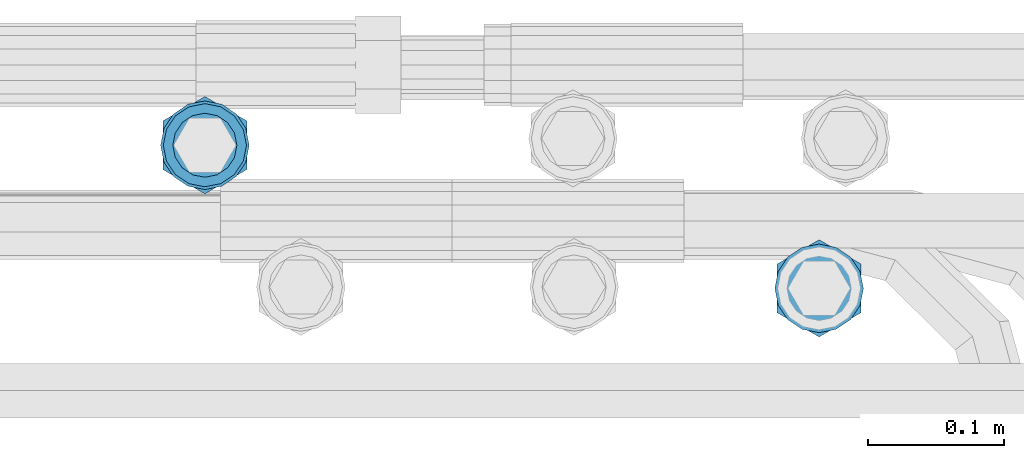
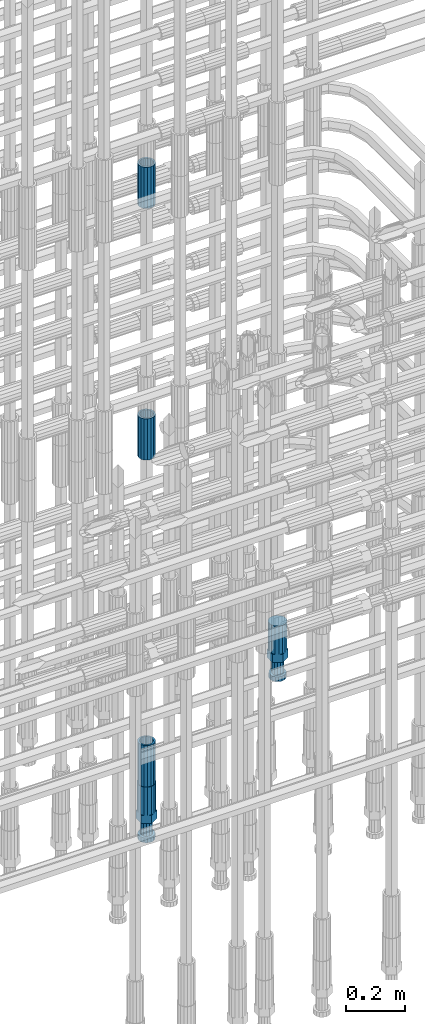
# One storey, part 74 of 119: 5 beams.
"""IFC2X3 building model written with IfcOpenShell, lengths in millimetres."""

import ifcopenshell
import ifcopenshell.guid

model = None  # the IFC model being written
_history = None  # IfcOwnerHistory: only IFC2X3 demands one
_inside = {}  # id of a spatial element -> (the spatial element, [elements in it])
_under = {}  # id of a project, library or spatial element -> (it, [spatial elements below it])
_declared = {}  # id of a project -> (the project, [libraries it declares])
_typed = {}  # id of a type object -> (the type object, [elements of that type])
_made_of = {}  # id of a material, layer set ... -> (it, [elements and type objects made of it])


def new_model(schema):
    """Start an empty IFC model of exactly this schema.

    Asked for "IFC4X3", IfcOpenShell would pick the latest addendum, in which some entities
    have other attributes; the version numbers below select the first issue.
    IFC2X3 requires an IfcOwnerHistory on every rooted entity: one is made here for all.
    """
    global model, _history
    if schema == "IFC4X3":
        model = ifcopenshell.file(schema_version=(4, 3, 0, 0))
    else:
        model = ifcopenshell.file(schema=schema)
    _inside.clear()
    _under.clear()
    _declared.clear()
    _typed.clear()
    _made_of.clear()
    _history = None
    if model.schema == "IFC2X3":
        org = make("IfcOrganization", Name="unknown")
        user = make(
            "IfcPersonAndOrganization",
            ThePerson=make("IfcPerson", FamilyName="unknown"),
            TheOrganization=org,
        )
        app = make(
            "IfcApplication",
            ApplicationDeveloper=org,
            Version="unknown",
            ApplicationFullName="unknown",
            ApplicationIdentifier="unknown",
        )
        _history = make(
            "IfcOwnerHistory",
            OwningUser=user,
            OwningApplication=app,
            ChangeAction="ADDED",
            CreationDate=0,
        )
    return model


def make(cls, **values):
    """One entity of the class cls with the attributes given. An attribute that is None is left unset."""
    return model.create_entity(
        cls, **{name: value for name, value in values.items() if value is not None}
    )


def rooted(cls, **values):
    """An entity with a GlobalId (a new one), such as an element, a storey or a relation."""
    return make(cls, GlobalId=ifcopenshell.guid.new(), OwnerHistory=_history, **values)


def si_unit(unit_type, name, prefix=None):
    """IfcSIUnit, for example si_unit("LENGTHUNIT", "METRE", prefix="MILLI")."""
    return make("IfcSIUnit", UnitType=unit_type, Prefix=prefix, Name=name)


def assignment(units):
    """IfcUnitAssignment: the units of a project."""
    return None if units is None else make("IfcUnitAssignment", Units=units)


def point(xyz):
    """IfcCartesianPoint."""
    return None if xyz is None else make("IfcCartesianPoint", Coordinates=xyz)


def direction(xyz):
    """IfcDirection."""
    return None if xyz is None else make("IfcDirection", DirectionRatios=xyz)


def frame(location, z_axis=None, x_axis=None):
    """IfcAxis2Placement3D, a coordinate frame: its origin and axes. An axis left out is left unset."""
    return make(
        "IfcAxis2Placement3D",
        Location=point(location),
        Axis=direction(z_axis),
        RefDirection=direction(x_axis),
    )


def origin_with_axes():
    """The frame at (0, 0, 0) with the z axis (0, 0, 1) and the x axis (1, 0, 0) written out."""
    return frame((0.0, 0.0, 0.0), z_axis=(0.0, 0.0, 1.0), x_axis=(1.0, 0.0, 0.0))


def place(relative_to, where):
    """IfcLocalPlacement: puts the frame where relative to a parent placement (None: the world)."""
    return make(
        "IfcLocalPlacement", PlacementRelTo=relative_to, RelativePlacement=where
    )


def context(
    kind, dimensions, precision=None, world=None, true_north=None, identifier=None
):
    """IfcGeometricRepresentationContext, for example the 3D "Model" context."""
    return make(
        "IfcGeometricRepresentationContext",
        ContextIdentifier=identifier,
        ContextType=kind,
        CoordinateSpaceDimension=dimensions,
        Precision=precision,
        WorldCoordinateSystem=world,
        TrueNorth=true_north,
    )


def subcontext(parent, identifier, kind, view, scale=None):
    """IfcGeometricRepresentationSubContext, for example "Body" below "Model"."""
    return make(
        "IfcGeometricRepresentationSubContext",
        ContextIdentifier=identifier,
        ContextType=kind,
        ParentContext=parent,
        TargetScale=scale,
        TargetView=view,
    )


def project(units=None, contexts=None):
    """IfcProject with its units and contexts."""
    return rooted(
        "IfcProject",
        Name="project",
        RepresentationContexts=contexts,
        UnitsInContext=assignment(units),
    )


def spatial(cls, under=None, at=None, **own):
    """A site, building, storey or space (cls), placed at a placement, below another one or the project."""
    s = rooted(cls, ObjectPlacement=at, **own)
    if under is not None:
        _under.setdefault(under.id(), (under, []))[1].append(s)
    return s


def faces_of(points, faces, orient=None, outer=None):
    """IfcFace entities. A face is a list of loops; a loop is a list of indices into points, from 0.

    orient and outer hold one flag for each loop. By default every Orientation is true, the
    first loop of a face is its IfcFaceOuterBound and the others are IfcFaceBound.
    """
    made = []
    for i, loops in enumerate(faces):
        bounds = []
        for j, loop in enumerate(loops):
            is_outer = j == 0 if outer is None else outer[i][j]
            bounds.append(
                make(
                    "IfcFaceOuterBound" if is_outer else "IfcFaceBound",
                    Bound=make("IfcPolyLoop", Polygon=[points[k] for k in loop]),
                    Orientation=True if orient is None else orient[i][j],
                )
            )
        made.append(make("IfcFace", Bounds=bounds))
    return made


def faceted_brep(points, faces, orient=None, outer=None, voids=None):
    """IfcFacetedBrep: a solid bounded by flat faces; with voids (closed shells), ...WithVoids."""
    shared = [point(p) for p in points]
    hull = make("IfcClosedShell", CfsFaces=faces_of(shared, faces, orient, outer))
    if voids is None:
        return make("IfcFacetedBrep", Outer=hull)
    return make(
        "IfcFacetedBrepWithVoids",
        Outer=hull,
        Voids=[
            make(cls, CfsFaces=faces_of(shared, fs, o, b)) for cls, fs, o, b in voids
        ],
    )


def shape(context_of_items, identifier, shape_type, items):
    """IfcShapeRepresentation: the items that make up one representation, for example the "Body"."""
    return make(
        "IfcShapeRepresentation",
        ContextOfItems=context_of_items,
        RepresentationIdentifier=identifier,
        RepresentationType=shape_type,
        Items=items,
    )


def material(Name=None, Category=None):
    """IfcMaterial."""
    return make("IfcMaterial", Name=Name, Category=Category)


def made_of(thing, what):
    """Note that an element or type object is made of a material, layer set ...; save() writes the relation."""
    if what is not None:
        _made_of.setdefault(what.id(), (what, []))[1].append(thing)
    return thing


def type_object(cls, material=None, **own):
    """A type object (cls), such as IfcWallType, which elements share."""
    return made_of(rooted(cls, **own), material)


def element(
    cls,
    number,
    at=None,
    inside=None,
    cuts=None,
    type_object=None,
    material=None,
    context=None,
    identifier="Body",
    shape_type=None,
    held_by="IfcProductDefinitionShape",
    body=None,
    shapes=None,
    **own,
):
    """One element of the class cls, such as IfcWall. Its Tag is "e" and its number.

    at: its placement. inside: the storey or other place that contains it. cuts: it is an
    opening in that element (IfcRelVoidsElement). A single representation is given by context,
    identifier, shape_type and body (its items); several are given by shapes. held_by: the class
    of the entity that holds the representations. save() writes the other relations.
    """
    e = rooted(cls, Tag="e%d" % number, ObjectPlacement=at, **own)
    if body is not None:
        shapes = [shape(context, identifier, shape_type, body)]
    if shapes is not None:
        e.Representation = make(held_by, Representations=shapes)
    if inside is not None:
        _inside.setdefault(inside.id(), (inside, []))[1].append(e)
    if cuts is not None:
        rooted(
            "IfcRelVoidsElement", RelatingBuildingElement=cuts, RelatedOpeningElement=e
        )
    if type_object is not None:
        _typed.setdefault(type_object.id(), (type_object, []))[1].append(e)
    return made_of(e, material)


def aggregate(whole, parts):
    """IfcRelAggregates: a whole, such as a stair, and the parts it consists of."""
    return rooted("IfcRelAggregates", RelatingObject=whole, RelatedObjects=parts)


def save(model, path):
    """Write the relations noted so far, then the file.

    IfcRelAggregates (storeys below a building ...), IfcRelContainedInSpatialStructure (elements
    in a storey), IfcRelDefinesByType, IfcRelAssociatesMaterial and IfcRelDeclares: one each for
    every whole, place, type object, material and project.
    """
    for whole, parts in _under.values():
        aggregate(whole, parts)
    for where, things in _inside.values():
        rooted(
            "IfcRelContainedInSpatialStructure",
            RelatedElements=things,
            RelatingStructure=where,
        )
    for kind, things in _typed.values():
        rooted("IfcRelDefinesByType", RelatedObjects=things, RelatingType=kind)
    for what, things in _made_of.values():
        rooted("IfcRelAssociatesMaterial", RelatedObjects=things, RelatingMaterial=what)
    for by, libraries in _declared.values():
        rooted("IfcRelDeclares", RelatingContext=by, RelatedDefinitions=libraries)
    model.write(path)


model = new_model("IFC2X3")

# Units and contexts
model_context = context("Model", 3, precision=1e-05, world=origin_with_axes())
body_context = subcontext(model_context, "Body", "Model", "MODEL_VIEW")
ifc_project = project(units=[si_unit("LENGTHUNIT", "METRE", prefix="MILLI"), si_unit("AREAUNIT", "SQUARE_METRE"), si_unit("VOLUMEUNIT", "CUBIC_METRE"), si_unit("MASSUNIT", "GRAM", prefix="KILO"), si_unit("TIMEUNIT", "SECOND"), si_unit("PLANEANGLEUNIT", "RADIAN"), si_unit("SOLIDANGLEUNIT", "STERADIAN"), si_unit("THERMODYNAMICTEMPERATUREUNIT", "DEGREE_CELSIUS"), si_unit("LUMINOUSINTENSITYUNIT", "LUMEN")], contexts=[model_context])

# Site, building, storey
site_placement = place(None, origin_with_axes())
site = spatial("IfcSite", under=ifc_project, at=site_placement, CompositionType="ELEMENT")
building_placement = place(site_placement, origin_with_axes())
building = spatial("IfcBuilding", under=site, at=building_placement, Name="Undefined", CompositionType="ELEMENT")
storey_placement = place(building_placement, origin_with_axes())
storey = spatial("IfcBuildingStorey", under=building, at=storey_placement, Name="Undefined", CompositionType="ELEMENT", Elevation=0.0)

# Beams
ifc_material = material(Name="STEEL/S275")
beam_type_1 = type_object("IfcBeamType", PredefinedType="NOTDEFINED")
beam_1_placement = place(storey_placement, frame((2035854.99840131, 6206340.98567718, 19667.7157291637), z_axis=(1.0, 0.0, 0.0), x_axis=(0.0, 0.0, 1.0)))
element("IfcBeam", 1, at=beam_1_placement, inside=storey, type_object=beam_type_1, material=ifc_material, Name="AG40N", context=body_context, shape_type="Brep", body=[
    faceted_brep([(1.62981450557709e-09, -23.4999999990687, 0.0), (7.45058059692383e-09, -21.7111690142192, 8.99306066057534), (170.000002125278, -21.711168999318, 8.99306066022245), (170.000002127141, -23.4999999844003, -3.66071617463604e-10), (4.65661287307739e-09, -16.6170093587134, 16.6170093578889), (170.000002122484, -16.6170093440451, 16.6170093575288), (1.86264514923096e-09, -8.99306066217832, 21.7111690140277), (170.000002118759, -8.99306064750999, 21.7111690136603), (2.3283064365387e-10, 9.31322574615479e-10, 23.5), (170.000002114102, 1.28056854009628e-08, 23.4999999996485), (-6.51925802230835e-09, 8.99306065868586, 21.7111690140241), (170.00000211224, 8.99306067335419, 21.7111690136639), (-7.45058059692383e-09, 16.6170093561523, 16.6170093578853), (170.000002109446, 16.6170093708206, 16.6170093575324), (-9.31322574615479e-09, 21.711169013055, 8.99306066057534), (170.000002108514, 21.7111690277234, 8.99306066022245), (-1.16415321826935e-09, 23.5000000009313, 0.0), (170.000002108514, 23.5000000144355, -3.66071617463604e-10), (-8.38190317153931e-09, 21.7111690151505, -8.99306066059444), (170.000002110377, 21.7111690300517, -8.9930606609546), (-5.58793544769287e-09, 16.6170093598776, -16.6170093579008), (170.000002113171, 16.6170093745459, -16.6170093582609), (-9.31322574615479e-10, 8.99306066334248, -21.7111690140396), (170.000002115965, 8.99306067801081, -21.7111690143961), (2.3283064365387e-10, 9.31322574615479e-10, -23.5), (170.00000211969, 1.7927959561348e-08, -23.5000000003843), (5.58793544769287e-09, -8.99306065752171, -21.7111690140396), (170.000002123415, -8.99306064285338, -21.7111690143961), (8.38190317153931e-09, -16.6170093549881, -16.6170093579008), (170.000002125278, -16.6170093403198, -16.6170093582646), (9.31322574615479e-09, -21.7111690121237, -8.99306066059444), (170.000002127141, -21.7111689972226, -8.9930606609546), (1.11758708953857e-08, -30.4999999990687, -9.54969436861575e-12), (1.30385160446167e-08, -28.1783257392235, -11.6718446871514), (170.000002129003, -28.1783257243223, -11.6718446875116), (170.000002129935, -30.4999999841675, -3.66071617463604e-10), (1.02445483207703e-08, -21.5667568228673, -21.5667568262129), (170.000002128072, -21.566756808199, -21.5667568265694), (7.45058059692383e-09, -11.6718446831219, -28.1783257416196), (170.000002125278, -11.6718446684536, -28.1783257419834), (3.72529029846191e-09, 3.95812094211578e-09, -30.5000000000277), (170.00000211969, 1.83936208486557e-08, -30.5000000003879), (-9.31322574615479e-10, 11.6718446905725, -28.1783257416232), (170.000002115965, 11.6718447052408, -28.1783257419797), (-6.51925802230835e-09, 21.5667568286881, -21.5667568262093), (170.000002110377, 21.5667568433564, -21.5667568265694), (-9.31322574615479e-09, 28.178325742716, -11.6718446871478), (170.000002108514, 28.1783257573843, -11.6718446875079), (-1.21071934700012e-08, 30.5, -5.91171556152403e-12), (170.000002106652, 30.5000000144355, -3.62433638656512e-10), (-1.21071934700012e-08, 28.1783257401548, 11.6718446871359), (170.00000210572, 28.1783257548232, 11.6718446867794), (-1.02445483207703e-08, 21.5667568240315, 21.5667568261974), (170.000002107583, 21.566756838467, 21.5667568258409), (-7.45058059692383e-09, 11.671844684286, 28.1783257416041), (170.000002110377, 11.6718446989544, 28.178325741244), (-2.79396772384644e-09, -2.56113708019257e-09, 30.5000000000159), (170.000002114102, 1.18743628263474e-08, 30.4999999996558), (1.86264514923096e-09, -11.6718446896411, 28.1783257416114), (170.000002118759, -11.67184467474, 28.178325741244), (7.45058059692383e-09, -21.5667568275239, 21.5667568261974), (170.000002123415, -21.5667568126228, 21.5667568258373), (1.02445483207703e-08, -28.1783257415518, 11.6718446871359), (170.000002127141, -28.1783257271163, 11.6718446867794)], [[[0, 1, 2, 3]], [[1, 4, 5, 2]], [[4, 6, 7, 5]], [[6, 8, 9, 7]], [[8, 10, 11, 9]], [[10, 12, 13, 11]], [[12, 14, 15, 13]], [[14, 16, 17, 15]], [[16, 18, 19, 17]], [[18, 20, 21, 19]], [[20, 22, 23, 21]], [[22, 24, 25, 23]], [[24, 26, 27, 25]], [[26, 28, 29, 27]], [[28, 30, 31, 29]], [[30, 0, 3, 31]], [[32, 33, 34, 35]], [[33, 36, 37, 34]], [[36, 38, 39, 37]], [[38, 40, 41, 39]], [[40, 42, 43, 41]], [[42, 44, 45, 43]], [[44, 46, 47, 45]], [[46, 48, 49, 47]], [[48, 50, 51, 49]], [[50, 52, 53, 51]], [[52, 54, 55, 53]], [[54, 56, 57, 55]], [[56, 58, 59, 57]], [[58, 60, 61, 59]], [[60, 62, 63, 61]], [[62, 32, 35, 63]], [[37, 39, 41, 43, 45, 47, 49, 51, 53, 55, 57, 59, 61, 63, 35, 34], [5, 7, 9, 11, 13, 15, 17, 19, 21, 23, 25, 27, 29, 31, 3, 2]], [[62, 60, 58, 56, 54, 52, 50, 48, 46, 44, 42, 40, 38, 36, 33, 32], [30, 28, 26, 24, 22, 20, 18, 16, 14, 12, 10, 8, 6, 4, 1, 0]]]),
])
beam_2_placement = place(storey_placement, frame((2035854.99840131, 6206340.98567718, 18490.9668583146), z_axis=(-0.99999999999998, 1.98000110685822e-07, 0.0), x_axis=(0.0, 0.0, -1.0)))
element("IfcBeam", 2, at=beam_2_placement, inside=storey, type_object=beam_type_1, material=ifc_material, Name="AG40N", context=body_context, shape_type="Brep", body=[
    faceted_brep([(1.62981450557709e-09, -23.4999999990687, 0.0), (7.45058059692383e-09, -21.7111690142192, 8.99306066057534), (170.000002125278, -21.711168999318, 8.99306066022245), (170.000002127141, -23.4999999844003, -3.66071617463604e-10), (4.65661287307739e-09, -16.6170093587134, 16.6170093578889), (170.000002122484, -16.6170093440451, 16.6170093575288), (1.86264514923096e-09, -8.99306066217832, 21.7111690140277), (170.000002118759, -8.99306064750999, 21.7111690136603), (2.3283064365387e-10, 9.31322574615479e-10, 23.5), (170.000002114102, 1.28056854009628e-08, 23.4999999996485), (-6.51925802230835e-09, 8.99306065868586, 21.7111690140241), (170.00000211224, 8.99306067335419, 21.7111690136639), (-7.45058059692383e-09, 16.6170093561523, 16.6170093578853), (170.000002109446, 16.6170093708206, 16.6170093575324), (-9.31322574615479e-09, 21.711169013055, 8.99306066057534), (170.000002108514, 21.7111690277234, 8.99306066022245), (-1.16415321826935e-09, 23.5000000009313, 0.0), (170.000002108514, 23.5000000144355, -3.66071617463604e-10), (-8.38190317153931e-09, 21.7111690151505, -8.99306066059444), (170.000002110377, 21.7111690300517, -8.9930606609546), (-5.58793544769287e-09, 16.6170093598776, -16.6170093579008), (170.000002113171, 16.6170093745459, -16.6170093582609), (-9.31322574615479e-10, 8.99306066334248, -21.7111690140396), (170.000002115965, 8.99306067801081, -21.7111690143961), (2.3283064365387e-10, 9.31322574615479e-10, -23.5), (170.00000211969, 1.7927959561348e-08, -23.5000000003843), (5.58793544769287e-09, -8.99306065752171, -21.7111690140396), (170.000002123415, -8.99306064285338, -21.7111690143961), (8.38190317153931e-09, -16.6170093549881, -16.6170093579008), (170.000002125278, -16.6170093403198, -16.6170093582646), (9.31322574615479e-09, -21.7111690121237, -8.99306066059444), (170.000002127141, -21.7111689972226, -8.9930606609546), (1.11758708953857e-08, -30.4999999990687, -9.54969436861575e-12), (1.30385160446167e-08, -28.1783257392235, -11.6718446871514), (170.000002129003, -28.1783257243223, -11.6718446875116), (170.000002129935, -30.4999999841675, -3.66071617463604e-10), (1.02445483207703e-08, -21.5667568228673, -21.5667568262129), (170.000002128072, -21.566756808199, -21.5667568265694), (7.45058059692383e-09, -11.6718446831219, -28.1783257416196), (170.000002125278, -11.6718446684536, -28.1783257419834), (3.72529029846191e-09, 3.95812094211578e-09, -30.5000000000277), (170.00000211969, 1.83936208486557e-08, -30.5000000003879), (-9.31322574615479e-10, 11.6718446905725, -28.1783257416232), (170.000002115965, 11.6718447052408, -28.1783257419797), (-6.51925802230835e-09, 21.5667568286881, -21.5667568262093), (170.000002110377, 21.5667568433564, -21.5667568265694), (-9.31322574615479e-09, 28.178325742716, -11.6718446871478), (170.000002108514, 28.1783257573843, -11.6718446875079), (-1.21071934700012e-08, 30.5, -5.91171556152403e-12), (170.000002106652, 30.5000000144355, -3.62433638656512e-10), (-1.21071934700012e-08, 28.1783257401548, 11.6718446871359), (170.00000210572, 28.1783257548232, 11.6718446867794), (-1.02445483207703e-08, 21.5667568240315, 21.5667568261974), (170.000002107583, 21.566756838467, 21.5667568258409), (-7.45058059692383e-09, 11.671844684286, 28.1783257416041), (170.000002110377, 11.6718446989544, 28.178325741244), (-2.79396772384644e-09, -2.56113708019257e-09, 30.5000000000159), (170.000002114102, 1.18743628263474e-08, 30.4999999996558), (1.86264514923096e-09, -11.6718446896411, 28.1783257416114), (170.000002118759, -11.67184467474, 28.178325741244), (7.45058059692383e-09, -21.5667568275239, 21.5667568261974), (170.000002123415, -21.5667568126228, 21.5667568258373), (1.02445483207703e-08, -28.1783257415518, 11.6718446871359), (170.000002127141, -28.1783257271163, 11.6718446867794)], [[[0, 1, 2, 3]], [[1, 4, 5, 2]], [[4, 6, 7, 5]], [[6, 8, 9, 7]], [[8, 10, 11, 9]], [[10, 12, 13, 11]], [[12, 14, 15, 13]], [[14, 16, 17, 15]], [[16, 18, 19, 17]], [[18, 20, 21, 19]], [[20, 22, 23, 21]], [[22, 24, 25, 23]], [[24, 26, 27, 25]], [[26, 28, 29, 27]], [[28, 30, 31, 29]], [[30, 0, 3, 31]], [[32, 33, 34, 35]], [[33, 36, 37, 34]], [[36, 38, 39, 37]], [[38, 40, 41, 39]], [[40, 42, 43, 41]], [[42, 44, 45, 43]], [[44, 46, 47, 45]], [[46, 48, 49, 47]], [[48, 50, 51, 49]], [[50, 52, 53, 51]], [[52, 54, 55, 53]], [[54, 56, 57, 55]], [[56, 58, 59, 57]], [[58, 60, 61, 59]], [[60, 62, 63, 61]], [[62, 32, 35, 63]], [[37, 39, 41, 43, 45, 47, 49, 51, 53, 55, 57, 59, 61, 63, 35, 34], [5, 7, 9, 11, 13, 15, 17, 19, 21, 23, 25, 27, 29, 31, 3, 2]], [[62, 60, 58, 56, 54, 52, 50, 48, 46, 44, 42, 40, 38, 36, 33, 32], [30, 28, 26, 24, 22, 20, 18, 16, 14, 12, 10, 8, 6, 4, 1, 0]]]),
])
beam_3_placement = place(storey_placement, frame((2035854.99840131, 6206340.98567718, 20704.6057291637), z_axis=(1.0, 0.0, 0.0), x_axis=(0.0, 0.0, 1.0)))
element("IfcBeam", 3, at=beam_3_placement, inside=storey, type_object=beam_type_1, material=ifc_material, Name="AG40N", context=body_context, shape_type="Brep", body=[
    faceted_brep([(1.62981450557709e-09, -23.4999999990687, 0.0), (7.45058059692383e-09, -21.7111690142192, 8.99306066057534), (170.000002125278, -21.711168999318, 8.99306066022245), (170.000002127141, -23.4999999844003, -3.66071617463604e-10), (4.65661287307739e-09, -16.6170093587134, 16.6170093578889), (170.000002122484, -16.6170093440451, 16.6170093575288), (1.86264514923096e-09, -8.99306066217832, 21.7111690140277), (170.000002118759, -8.99306064750999, 21.7111690136603), (2.3283064365387e-10, 9.31322574615479e-10, 23.5), (170.000002114102, 1.28056854009628e-08, 23.4999999996485), (-6.51925802230835e-09, 8.99306065868586, 21.7111690140241), (170.00000211224, 8.99306067335419, 21.7111690136639), (-7.45058059692383e-09, 16.6170093561523, 16.6170093578853), (170.000002109446, 16.6170093708206, 16.6170093575324), (-9.31322574615479e-09, 21.711169013055, 8.99306066057534), (170.000002108514, 21.7111690277234, 8.99306066022245), (-1.16415321826935e-09, 23.5000000009313, 0.0), (170.000002108514, 23.5000000144355, -3.66071617463604e-10), (-8.38190317153931e-09, 21.7111690151505, -8.99306066059444), (170.000002110377, 21.7111690300517, -8.9930606609546), (-5.58793544769287e-09, 16.6170093598776, -16.6170093579008), (170.000002113171, 16.6170093745459, -16.6170093582609), (-9.31322574615479e-10, 8.99306066334248, -21.7111690140396), (170.000002115965, 8.99306067801081, -21.7111690143961), (2.3283064365387e-10, 9.31322574615479e-10, -23.5), (170.00000211969, 1.7927959561348e-08, -23.5000000003843), (5.58793544769287e-09, -8.99306065752171, -21.7111690140396), (170.000002123415, -8.99306064285338, -21.7111690143961), (8.38190317153931e-09, -16.6170093549881, -16.6170093579008), (170.000002125278, -16.6170093403198, -16.6170093582646), (9.31322574615479e-09, -21.7111690121237, -8.99306066059444), (170.000002127141, -21.7111689972226, -8.9930606609546), (1.11758708953857e-08, -30.4999999990687, -9.54969436861575e-12), (1.30385160446167e-08, -28.1783257392235, -11.6718446871514), (170.000002129003, -28.1783257243223, -11.6718446875116), (170.000002129935, -30.4999999841675, -3.66071617463604e-10), (1.02445483207703e-08, -21.5667568228673, -21.5667568262129), (170.000002128072, -21.566756808199, -21.5667568265694), (7.45058059692383e-09, -11.6718446831219, -28.1783257416196), (170.000002125278, -11.6718446684536, -28.1783257419834), (3.72529029846191e-09, 3.95812094211578e-09, -30.5000000000277), (170.00000211969, 1.83936208486557e-08, -30.5000000003879), (-9.31322574615479e-10, 11.6718446905725, -28.1783257416232), (170.000002115965, 11.6718447052408, -28.1783257419797), (-6.51925802230835e-09, 21.5667568286881, -21.5667568262093), (170.000002110377, 21.5667568433564, -21.5667568265694), (-9.31322574615479e-09, 28.178325742716, -11.6718446871478), (170.000002108514, 28.1783257573843, -11.6718446875079), (-1.21071934700012e-08, 30.5, -5.91171556152403e-12), (170.000002106652, 30.5000000144355, -3.62433638656512e-10), (-1.21071934700012e-08, 28.1783257401548, 11.6718446871359), (170.00000210572, 28.1783257548232, 11.6718446867794), (-1.02445483207703e-08, 21.5667568240315, 21.5667568261974), (170.000002107583, 21.566756838467, 21.5667568258409), (-7.45058059692383e-09, 11.671844684286, 28.1783257416041), (170.000002110377, 11.6718446989544, 28.178325741244), (-2.79396772384644e-09, -2.56113708019257e-09, 30.5000000000159), (170.000002114102, 1.18743628263474e-08, 30.4999999996558), (1.86264514923096e-09, -11.6718446896411, 28.1783257416114), (170.000002118759, -11.67184467474, 28.178325741244), (7.45058059692383e-09, -21.5667568275239, 21.5667568261974), (170.000002123415, -21.5667568126228, 21.5667568258373), (1.02445483207703e-08, -28.1783257415518, 11.6718446871359), (170.000002127141, -28.1783257271163, 11.6718446867794)], [[[0, 1, 2, 3]], [[1, 4, 5, 2]], [[4, 6, 7, 5]], [[6, 8, 9, 7]], [[8, 10, 11, 9]], [[10, 12, 13, 11]], [[12, 14, 15, 13]], [[14, 16, 17, 15]], [[16, 18, 19, 17]], [[18, 20, 21, 19]], [[20, 22, 23, 21]], [[22, 24, 25, 23]], [[24, 26, 27, 25]], [[26, 28, 29, 27]], [[28, 30, 31, 29]], [[30, 0, 3, 31]], [[32, 33, 34, 35]], [[33, 36, 37, 34]], [[36, 38, 39, 37]], [[38, 40, 41, 39]], [[40, 42, 43, 41]], [[42, 44, 45, 43]], [[44, 46, 47, 45]], [[46, 48, 49, 47]], [[48, 50, 51, 49]], [[50, 52, 53, 51]], [[52, 54, 55, 53]], [[54, 56, 57, 55]], [[56, 58, 59, 57]], [[58, 60, 61, 59]], [[60, 62, 63, 61]], [[62, 32, 35, 63]], [[37, 39, 41, 43, 45, 47, 49, 51, 53, 55, 57, 59, 61, 63, 35, 34], [5, 7, 9, 11, 13, 15, 17, 19, 21, 23, 25, 27, 29, 31, 3, 2]], [[62, 60, 58, 56, 54, 52, 50, 48, 46, 44, 42, 40, 38, 36, 33, 32], [30, 28, 26, 24, 22, 20, 18, 16, 14, 12, 10, 8, 6, 4, 1, 0]]]),
])
beam_type_2 = type_object("IfcBeamType", Name="ROD65", PredefinedType="NOTDEFINED")
beam_4_placement = place(storey_placement, frame((2036305.58866833, 6206235.98579162, 18890.9668583146), z_axis=(-0.99999999999998, 1.98000110685822e-07, 0.0), x_axis=(0.0, 0.0, -1.0)))
element("IfcBeam", 4, at=beam_4_placement, inside=storey, type_object=beam_type_2, material=ifc_material, Name="AGB40", ObjectType="ROD65", context=body_context, shape_type="Brep", body=[
    faceted_brep([(116.999999999069, 17.8249999252148, 30.8738056446964), (116.999999998137, 22.0056957420893, 23.632628078838), (116.999999999069, 12.4372115600854, 30.0260848066173), (116.999999999069, 8.17543111252598, 30.8738056446964), (117.000000000931, -17.8250000746921, 30.8738056446964), (150.200000001118, -17.8250000723638, 30.8738056446964), (150.199999999255, 17.8249999275431, 30.8738056446964), (117.000000000931, -8.17543109622784, 30.8738056446964), (117.000000001863, -22.0056959956419, 23.6326278985034), (117.000000000931, -12.4372115437873, 30.0260848066173), (117.000000001863, -35.6500000746455, -2.18278728425503e-10), (150.200000002049, -35.6500000723172, -2.18278728425503e-10), (117.000000001863, -30.8443149488885, 8.32369080289209), (117.000000001863, -30.8443149488885, -8.32369080355784), (117.000000002794, -32.4999999918509, 0.0), (117.000000000931, -17.8250000746921, -30.873805645133), (150.200000001118, -17.8250000723638, -30.873805645133), (117.000000001863, -22.0056959961075, -23.6326278982269), (117.000000000931, -8.17543109389953, -30.873805645133), (117.000000000931, -12.4372115437873, -30.0260848066173), (116.999999999069, 17.8249999252148, -30.873805645133), (150.199999999255, 17.8249999275431, -30.873805645133), (116.999999999069, 8.17543111019768, -30.873805645133), (116.999999999069, 12.4372115600854, -30.0260848066173), (116.999999998137, 22.005695742555, -23.6326280785652), (116.999999998137, 35.6499999251682, -2.18278728425503e-10), (150.199999998324, 35.6499999277294, -2.18278728425503e-10), (116.999999998137, 30.8443150522653, -8.32369036550881), (116.999999997206, 32.5000000081491, 0.0), (116.999999998137, 30.8443150522653, 8.32369036483942), (1.86264514923096e-09, -22.9809703885112, 22.9809703885621), (1.86264514923096e-09, -30.0260848065373, 12.4372115518672), (117.000000001863, -30.0260847983882, 12.4372115518672), (117.000000001863, -22.9809703803621, 22.9809703885621), (-1.86264514923096e-09, 22.9809703885112, -22.9809703885621), (-1.86264514923096e-09, 30.0260848065373, -12.4372115518672), (116.999999998137, 30.0260848146863, -12.4372115518672), (116.999999998137, 22.9809703966603, -22.9809703885621), (1.86264514923096e-09, -30.0260848065373, -12.4372115518672), (1.86264514923096e-09, -22.9809703885112, -22.9809703885621), (117.000000001863, -22.9809703803621, -22.9809703885621), (117.000000001863, -30.0260847983882, -12.4372115518672), (9.31322574615479e-10, -12.4372115519363, 30.0260848066173), (0.0, 0.0, 32.5), (-9.31322574615479e-10, 12.4372115519363, 30.0260848066173), (-1.86264514923096e-09, 22.9809703885112, 22.9809703885621), (-1.86264514923096e-09, 30.0260848065373, 12.4372115518672), (-2.79396772384644e-09, 32.5, 0.0), (-9.31322574615479e-10, 12.4372115519363, -30.0260848066173), (0.0, 0.0, -32.5), (9.31322574615479e-10, -12.4372115519363, -30.0260848066173), (2.79396772384644e-09, -32.5, 0.0), (116.999999998137, 22.9809703966603, 22.9809703885621), (116.999999998137, 30.0260848146863, 12.4372115518672), (117.0, 8.14907252788544e-09, -32.5), (117.0, 8.14907252788544e-09, 32.5), (150.200000000186, -10.5000000959262, 18.1865334791873), (150.199999999255, -9.59262251853943e-08, 20.9999999997126), (150.199999998324, 10.4999999040738, 18.1865334791873), (150.199999997392, 18.1865333835594, 10.4999999997126), (150.199999997392, 20.9999999040738, -2.87400325760245e-10), (150.199999997392, 18.1865333835594, -10.5000000002874), (150.199999998324, 10.4999999040738, -18.1865334797621), (150.199999999255, -9.59262251853943e-08, -21.0000000002874), (150.200000000186, -10.5000000959262, -18.1865334797621), (150.200000000186, -18.1865335754119, -10.5000000002874), (150.200000001118, -21.0000000959262, -2.87400325760245e-10), (150.200000000186, -18.1865335754119, 10.4999999997126), (210.979999999516, 10.4999999082647, 18.1865334791873), (210.979999999516, -9.17352735996246e-08, 20.9999999997126), (210.979999997653, 18.1865333877504, 10.4999999997126), (210.979999997653, 20.9999999082647, -2.87400325760245e-10), (210.979999997653, 18.1865333877504, -10.5000000002874), (210.979999999516, 10.4999999082647, -18.1865334797621), (210.979999999516, -9.17352735996246e-08, -21.0000000002874), (210.979999999516, -10.5000000917353, -18.1865334797621), (210.980000000447, -18.1865335712209, -10.5000000002874), (210.980000001378, -21.0000000917353, -2.87400325760245e-10), (210.980000000447, -18.1865335712209, 10.4999999997126), (210.979999999516, -10.5000000917353, 18.1865334791873), (211.001368402503, -27.7269939335529, -11.4911163272045), (211.003082515672, -21.2238095656503, -21.2238154190527), (231.002518340945, -21.2131946226582, -21.2132004554769), (231.000804228708, -27.7163789905608, -11.4805013636287), (211.001368415542, -11.4911086384673, -27.7269970399575), (231.000804241747, -11.4804936954752, -27.7163820763781), (210.996487061493, -0.0106066407170147, -30.0106107396168), (230.995922887698, 8.30227509140968e-06, -29.999995776041), (210.98918159306, 11.4698940692469, -27.7269970332745), (230.988617419265, 11.4805090120062, -27.7163820696951), (210.980564201251, 21.2025913291145, -21.2238154067054), (230.980000027455, 21.2132062721066, -21.2132004431296), (210.971946807578, 27.7057702087332, -11.4911163110701), (230.971382633783, 27.7163851517253, -11.4805013474943), (210.964641331695, 29.9893806746695, -0.0106149565435771), (230.9640771579, 29.9999956176616, 7.03221303410828e-09), (210.959759964608, 27.7057637346443, 11.4698863966551), (230.959195790812, 27.7163786776364, 11.4805013602345), (210.958045851439, 21.2025793667417, 21.2025854885032), (230.957481677644, 21.2131943097338, 21.2132004520827), (210.959759951569, 11.4698784395587, 27.705767109408), (230.959195776843, 11.4804933823179, 27.7163820729838), (210.964641305618, -0.0106235581915826, 29.9893808090674), (230.964077131823, -8.61519947648048e-06, 29.9999957726432), (210.971946774051, -11.4911242681555, 27.7057671027251), (230.971382599324, -11.4805093251634, 27.7163820663009), (210.98056416586, -21.2238215280231, 21.2025854761559), (230.979999991134, -21.2132065852638, 21.2132004397354), (210.989181559533, -27.7270004076418, 11.4698863805206), (230.988617384806, -27.7163854646496, 11.4805013441), (210.996487035416, -30.0106108735781, -0.0106149740058754), (230.995922861621, -29.999995930586, -1.04300852399319e-08)], [[[0, 1, 2, 3]], [[4, 5, 6, 0, 3, 7]], [[8, 4, 7, 9]], [[10, 11, 5, 4, 8, 12]], [[13, 10, 12, 14]], [[15, 16, 11, 10, 13, 17]], [[18, 15, 17, 19]], [[20, 21, 16, 15, 18, 22]], [[20, 22, 23, 24]], [[25, 26, 21, 20, 24, 27]], [[25, 27, 28, 29]], [[30, 31, 32, 33]], [[34, 35, 36, 37]], [[38, 39, 40, 41]], [[31, 30, 42, 43, 44, 45, 46, 47, 35, 34, 48, 49, 50, 39, 38, 51]], [[46, 45, 52, 53]], [[28, 47, 46, 53, 29]], [[27, 36, 35, 47, 28]], [[24, 37, 36, 27]], [[23, 48, 34, 37, 24]], [[22, 54, 49, 48, 23]], [[18, 54, 22]], [[19, 50, 49, 54, 18]], [[17, 40, 39, 50, 19]], [[13, 41, 40, 17]], [[14, 51, 38, 41, 13]], [[12, 32, 31, 51, 14]], [[8, 33, 32, 12]], [[9, 42, 30, 33, 8]], [[7, 55, 43, 42, 9]], [[3, 55, 7]], [[2, 44, 43, 55, 3]], [[1, 52, 45, 44, 2]], [[29, 53, 52, 1]], [[0, 6, 26, 25, 29, 1]], [[5, 11, 16, 21, 26, 6], [56, 57, 58, 59, 60, 61, 62, 63, 64, 65, 66, 67]], [[68, 58, 57, 69]], [[70, 59, 58, 68]], [[71, 60, 59, 70]], [[72, 61, 60, 71]], [[73, 62, 61, 72]], [[74, 63, 62, 73]], [[75, 64, 63, 74]], [[76, 65, 64, 75]], [[77, 66, 65, 76]], [[78, 67, 66, 77]], [[79, 56, 67, 78]], [[69, 57, 56, 79]], [[80, 81, 82, 83]], [[81, 84, 85, 82]], [[84, 86, 87, 85]], [[86, 88, 89, 87]], [[88, 90, 91, 89]], [[90, 92, 93, 91]], [[92, 94, 95, 93]], [[94, 96, 97, 95]], [[96, 98, 99, 97]], [[98, 100, 101, 99]], [[100, 102, 103, 101]], [[102, 104, 105, 103]], [[104, 106, 107, 105]], [[106, 108, 109, 107]], [[108, 110, 111, 109]], [[82, 85, 87, 89, 91, 93, 95, 97, 99, 101, 103, 105, 107, 109, 111, 83]], [[110, 80, 83, 111]], [[108, 106, 104, 102, 100, 98, 96, 94, 92, 90, 88, 86, 84, 81, 80, 110], [78, 77, 76, 75, 74, 73, 72, 71, 70, 68, 69, 79]]]),
])
beam_5_placement = place(storey_placement, frame((2035854.99840131, 6206340.98567718, 18320.9668583146), z_axis=(-0.99999999999998, 1.98000110685822e-07, 0.0), x_axis=(0.0, 0.0, -1.0)))
element("IfcBeam", 5, at=beam_5_placement, inside=storey, type_object=beam_type_2, material=ifc_material, Name="AGB40", ObjectType="ROD65", context=body_context, shape_type="Brep", body=[
    faceted_brep([(116.999999999069, 17.8249999252148, 30.8738056446964), (116.999999998137, 22.0056957420893, 23.632628078838), (116.999999999069, 12.4372115600854, 30.0260848066173), (116.999999999069, 8.17543111252598, 30.8738056446964), (117.000000000931, -17.8250000746921, 30.8738056446964), (150.200000001118, -17.8250000723638, 30.8738056446964), (150.199999999255, 17.8249999275431, 30.8738056446964), (117.000000000931, -8.17543109622784, 30.8738056446964), (117.000000001863, -22.0056959956419, 23.6326278985034), (117.000000000931, -12.4372115437873, 30.0260848066173), (117.000000001863, -35.6500000746455, -2.18278728425503e-10), (150.200000002049, -35.6500000723172, -2.18278728425503e-10), (117.000000001863, -30.8443149488885, 8.32369080289209), (117.000000001863, -30.8443149488885, -8.32369080355784), (117.000000002794, -32.4999999918509, 0.0), (117.000000000931, -17.8250000746921, -30.873805645133), (150.200000001118, -17.8250000723638, -30.873805645133), (117.000000001863, -22.0056959961075, -23.6326278982269), (117.000000000931, -8.17543109389953, -30.873805645133), (117.000000000931, -12.4372115437873, -30.0260848066173), (116.999999999069, 17.8249999252148, -30.873805645133), (150.199999999255, 17.8249999275431, -30.873805645133), (116.999999999069, 8.17543111019768, -30.873805645133), (116.999999999069, 12.4372115600854, -30.0260848066173), (116.999999998137, 22.005695742555, -23.6326280785652), (116.999999998137, 35.6499999251682, -2.18278728425503e-10), (150.199999998324, 35.6499999277294, -2.18278728425503e-10), (116.999999998137, 30.8443150522653, -8.32369036550881), (116.999999997206, 32.5000000081491, 0.0), (116.999999998137, 30.8443150522653, 8.32369036483942), (1.86264514923096e-09, -22.9809703885112, 22.9809703885621), (1.86264514923096e-09, -30.0260848065373, 12.4372115518672), (117.000000001863, -30.0260847983882, 12.4372115518672), (117.000000001863, -22.9809703803621, 22.9809703885621), (-1.86264514923096e-09, 22.9809703885112, -22.9809703885621), (-1.86264514923096e-09, 30.0260848065373, -12.4372115518672), (116.999999998137, 30.0260848146863, -12.4372115518672), (116.999999998137, 22.9809703966603, -22.9809703885621), (1.86264514923096e-09, -30.0260848065373, -12.4372115518672), (1.86264514923096e-09, -22.9809703885112, -22.9809703885621), (117.000000001863, -22.9809703803621, -22.9809703885621), (117.000000001863, -30.0260847983882, -12.4372115518672), (9.31322574615479e-10, -12.4372115519363, 30.0260848066173), (0.0, 0.0, 32.5), (-9.31322574615479e-10, 12.4372115519363, 30.0260848066173), (-1.86264514923096e-09, 22.9809703885112, 22.9809703885621), (-1.86264514923096e-09, 30.0260848065373, 12.4372115518672), (-2.79396772384644e-09, 32.5, 0.0), (-9.31322574615479e-10, 12.4372115519363, -30.0260848066173), (0.0, 0.0, -32.5), (9.31322574615479e-10, -12.4372115519363, -30.0260848066173), (2.79396772384644e-09, -32.5, 0.0), (116.999999998137, 22.9809703966603, 22.9809703885621), (116.999999998137, 30.0260848146863, 12.4372115518672), (117.0, 8.14907252788544e-09, -32.5), (117.0, 8.14907252788544e-09, 32.5), (150.200000000186, -10.5000000959262, 18.1865334791873), (150.199999999255, -9.59262251853943e-08, 20.9999999997126), (150.199999998324, 10.4999999040738, 18.1865334791873), (150.199999997392, 18.1865333835594, 10.4999999997126), (150.199999997392, 20.9999999040738, -2.87400325760245e-10), (150.199999997392, 18.1865333835594, -10.5000000002874), (150.199999998324, 10.4999999040738, -18.1865334797621), (150.199999999255, -9.59262251853943e-08, -21.0000000002874), (150.200000000186, -10.5000000959262, -18.1865334797621), (150.200000000186, -18.1865335754119, -10.5000000002874), (150.200000001118, -21.0000000959262, -2.87400325760245e-10), (150.200000000186, -18.1865335754119, 10.4999999997126), (210.979999999516, 10.4999999082647, 18.1865334791873), (210.979999999516, -9.17352735996246e-08, 20.9999999997126), (210.979999997653, 18.1865333877504, 10.4999999997126), (210.979999997653, 20.9999999082647, -2.87400325760245e-10), (210.979999997653, 18.1865333877504, -10.5000000002874), (210.979999999516, 10.4999999082647, -18.1865334797621), (210.979999999516, -9.17352735996246e-08, -21.0000000002874), (210.979999999516, -10.5000000917353, -18.1865334797621), (210.980000000447, -18.1865335712209, -10.5000000002874), (210.980000001378, -21.0000000917353, -2.87400325760245e-10), (210.980000000447, -18.1865335712209, 10.4999999997126), (210.979999999516, -10.5000000917353, 18.1865334791873), (211.001368402503, -27.7269939335529, -11.4911163272045), (211.003082515672, -21.2238095656503, -21.2238154190527), (231.002518340945, -21.2131946226582, -21.2132004554769), (231.000804228708, -27.7163789905608, -11.4805013636287), (211.001368415542, -11.4911086384673, -27.7269970399575), (231.000804241747, -11.4804936954752, -27.7163820763781), (210.996487061493, -0.0106066407170147, -30.0106107396168), (230.995922887698, 8.30227509140968e-06, -29.999995776041), (210.98918159306, 11.4698940692469, -27.7269970332745), (230.988617419265, 11.4805090120062, -27.7163820696951), (210.980564201251, 21.2025913291145, -21.2238154067054), (230.980000027455, 21.2132062721066, -21.2132004431296), (210.971946807578, 27.7057702087332, -11.4911163110701), (230.971382633783, 27.7163851517253, -11.4805013474943), (210.964641331695, 29.9893806746695, -0.0106149565435771), (230.9640771579, 29.9999956176616, 7.03221303410828e-09), (210.959759964608, 27.7057637346443, 11.4698863966551), (230.959195790812, 27.7163786776364, 11.4805013602345), (210.958045851439, 21.2025793667417, 21.2025854885032), (230.957481677644, 21.2131943097338, 21.2132004520827), (210.959759951569, 11.4698784395587, 27.705767109408), (230.959195776843, 11.4804933823179, 27.7163820729838), (210.964641305618, -0.0106235581915826, 29.9893808090674), (230.964077131823, -8.61519947648048e-06, 29.9999957726432), (210.971946774051, -11.4911242681555, 27.7057671027251), (230.971382599324, -11.4805093251634, 27.7163820663009), (210.98056416586, -21.2238215280231, 21.2025854761559), (230.979999991134, -21.2132065852638, 21.2132004397354), (210.989181559533, -27.7270004076418, 11.4698863805206), (230.988617384806, -27.7163854646496, 11.4805013441), (210.996487035416, -30.0106108735781, -0.0106149740058754), (230.995922861621, -29.999995930586, -1.04300852399319e-08)], [[[0, 1, 2, 3]], [[4, 5, 6, 0, 3, 7]], [[8, 4, 7, 9]], [[10, 11, 5, 4, 8, 12]], [[13, 10, 12, 14]], [[15, 16, 11, 10, 13, 17]], [[18, 15, 17, 19]], [[20, 21, 16, 15, 18, 22]], [[20, 22, 23, 24]], [[25, 26, 21, 20, 24, 27]], [[25, 27, 28, 29]], [[30, 31, 32, 33]], [[34, 35, 36, 37]], [[38, 39, 40, 41]], [[31, 30, 42, 43, 44, 45, 46, 47, 35, 34, 48, 49, 50, 39, 38, 51]], [[46, 45, 52, 53]], [[28, 47, 46, 53, 29]], [[27, 36, 35, 47, 28]], [[24, 37, 36, 27]], [[23, 48, 34, 37, 24]], [[22, 54, 49, 48, 23]], [[18, 54, 22]], [[19, 50, 49, 54, 18]], [[17, 40, 39, 50, 19]], [[13, 41, 40, 17]], [[14, 51, 38, 41, 13]], [[12, 32, 31, 51, 14]], [[8, 33, 32, 12]], [[9, 42, 30, 33, 8]], [[7, 55, 43, 42, 9]], [[3, 55, 7]], [[2, 44, 43, 55, 3]], [[1, 52, 45, 44, 2]], [[29, 53, 52, 1]], [[0, 6, 26, 25, 29, 1]], [[5, 11, 16, 21, 26, 6], [56, 57, 58, 59, 60, 61, 62, 63, 64, 65, 66, 67]], [[68, 58, 57, 69]], [[70, 59, 58, 68]], [[71, 60, 59, 70]], [[72, 61, 60, 71]], [[73, 62, 61, 72]], [[74, 63, 62, 73]], [[75, 64, 63, 74]], [[76, 65, 64, 75]], [[77, 66, 65, 76]], [[78, 67, 66, 77]], [[79, 56, 67, 78]], [[69, 57, 56, 79]], [[80, 81, 82, 83]], [[81, 84, 85, 82]], [[84, 86, 87, 85]], [[86, 88, 89, 87]], [[88, 90, 91, 89]], [[90, 92, 93, 91]], [[92, 94, 95, 93]], [[94, 96, 97, 95]], [[96, 98, 99, 97]], [[98, 100, 101, 99]], [[100, 102, 103, 101]], [[102, 104, 105, 103]], [[104, 106, 107, 105]], [[106, 108, 109, 107]], [[108, 110, 111, 109]], [[82, 85, 87, 89, 91, 93, 95, 97, 99, 101, 103, 105, 107, 109, 111, 83]], [[110, 80, 83, 111]], [[108, 106, 104, 102, 100, 98, 96, 94, 92, 90, 88, 86, 84, 81, 80, 110], [78, 77, 76, 75, 74, 73, 72, 71, 70, 68, 69, 79]]]),
])

save(model, "model.ifc")
